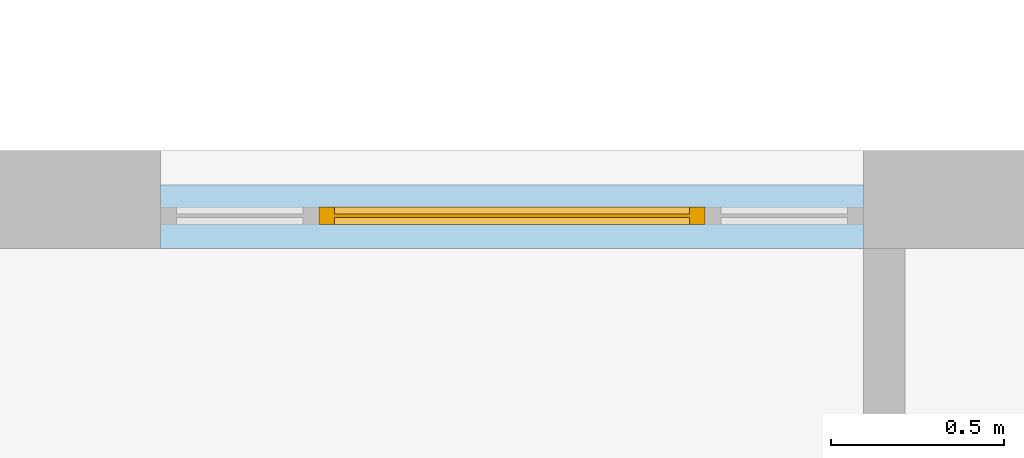
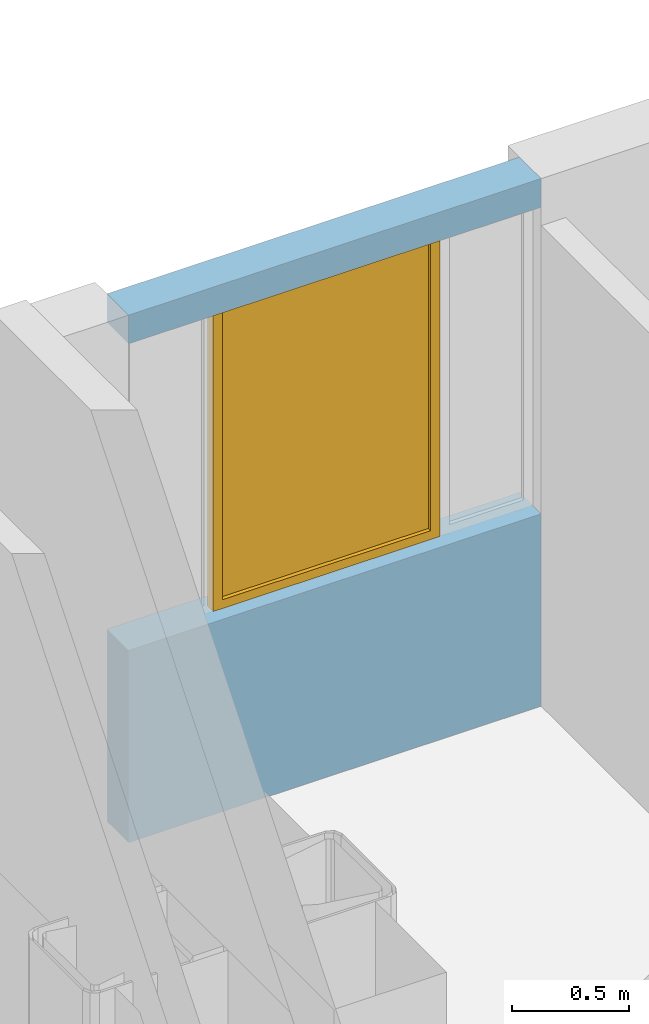
# One storey, part 19 of 64: 1 window, 3 openings, plus 1 element that does not belong to this part.
"""IFC4 building model written with IfcOpenShell, lengths in feet."""

from ifc_helpers import new_model, entity, si_unit, converted_unit, frame, origin_with_axes, origin_2d_with_axis, place, context, subcontext, project, spatial, line, indexed_curve, outline, extrude, polygons, source, transform, mapped, material, layer, layer_set, layer_usage, type_object, type_shapes, element, fill, save


model = new_model("IFC4")

# Units and contexts
model_context = context("Model", 3, precision=1e-05, world=origin_with_axes())
plan_context = context("Plan", 2, precision=1e-05, world=origin_2d_with_axis())
context_of_model_1 = context(None, 3, precision=1e-05, world=origin_with_axes())
context_of_model_2 = context(None, 3, precision=1e-05, world=origin_with_axes())
body_context = subcontext(model_context, "Body", "Model", "MODEL_VIEW")
ifc_project = project(units=[converted_unit("PLANEANGLEUNIT", "degree", entity("IfcReal", 0.0174532925199433), si_unit("PLANEANGLEUNIT", "RADIAN"), dimensions=[0, 0, 0, 0, 0, 0, 0]), converted_unit("AREAUNIT", "square foot", entity("IfcReal", 0.09290304), si_unit("AREAUNIT", "SQUARE_METRE"), dimensions=[2, 0, 0, 0, 0, 0, 0]), converted_unit("LENGTHUNIT", "foot", entity("IfcReal", 0.3048), si_unit("LENGTHUNIT", "METRE"), dimensions=[1, 0, 0, 0, 0, 0, 0]), converted_unit("VOLUMEUNIT", "cubic foot", entity("IfcReal", 0.0283168467116885), si_unit("VOLUMEUNIT", "CUBIC_METRE"), dimensions=[3, 0, 0, 0, 0, 0, 0])], contexts=[model_context, plan_context, context_of_model_1, context_of_model_2])

# Site, building, storey
site_placement = place(None, origin_with_axes())
site = spatial("IfcSite", under=ifc_project, at=site_placement)
building_placement = place(site_placement, origin_with_axes())
building = spatial("IfcBuilding", under=site, at=building_placement, Name="Building")
storey_placement = place(building_placement, origin_with_axes())
storey = spatial("IfcBuildingStorey", under=building, at=storey_placement, Name="Storey")

# Wall, openings, window
ifc_material_1 = material()
ifc_layer_1 = layer(ifc_material_1, 0.0520833333333333)
ifc_material_2 = material()
ifc_layer_2 = layer(ifc_material_2, 0.458332985639572)
ifc_layer_3 = layer(ifc_material_1, 0.0520833320915699)
ifc_material_3 = material(Name="SPACE")
ifc_layer_4 = layer(ifc_material_3, 0.0416669994592667, Name="Siding")
ifc_layer_set = layer_set([ifc_layer_1, ifc_layer_2, ifc_layer_3, ifc_layer_4], Name="poche")
ifc_layer_usage = layer_usage(ifc_layer_set, "AXIS2", "POSITIVE", 0.0)
wall_type = type_object("IfcWallType", PredefinedType="STANDARD", material=ifc_layer_set)
wall_placement = place(storey_placement, frame((-264.65418457672, 33.9619600240953, 0.0), z_axis=(0.0, 0.0, 1.0), x_axis=(1.0, 0.0, 0.0)))
wall = element("IfcWall", 1, at=wall_placement, inside=storey, type_object=wall_type, material=ifc_layer_usage, Name="Wall", context=body_context, shape_type="SweptSolid", body=[
    extrude(outline(indexed_curve([(0.0, 0.0), (0.0, 0.604166650523742), (6.65892436578507, 0.604166650523742), (6.65892436578507, 0.0), (0.0, 0.0)], self_intersect=False)), origin_with_axes(), (0.0, 0.0, 1.0), 9.00000020900736),
])
shared_shape_1 = source(origin_with_axes(), body_context, "Body", "SweptSolid", [
    extrude(outline(indexed_curve([(0.0, 0.0), (1.49999189376831, 0.0), (1.49999189376831, 5.23353862762451), (0.0, 5.23353862762451)], segments=[line(1, 2, 3, 4, 1)])), frame((0.0, -0.328083992004395, 0.0), z_axis=(0.0, -1.0, 0.0), x_axis=(1.0, 0.0, 0.0)), (0.0, 0.0, -1.0), 1.26033463072902),
])
opening_1_placement = place(wall_placement, frame((-3.49676543189026e-13, -2.91397119324188e-14, 3.28083989501312), z_axis=(0.0, 0.0, 1.0), x_axis=(1.0, 0.0, 0.0)))
element("IfcOpeningElement", 2, at=opening_1_placement, cuts=wall, Name="Opening", PredefinedType="OPENING", context=body_context, shape_type="MappedRepresentation", body=[
    mapped(shared_shape_1, transform((0.0, 0.0, 0.0), x_axis=(1.0, 0.0, 0.0), y_axis=(0.0, 1.0, 0.0), z_axis=(0.0, 0.0, 1.0), scale=1.0)),
])
opening_2_placement = place(wall_placement, frame((5.15891498155133, -2.91397119324188e-14, 3.28083989501312), z_axis=(0.0, 0.0, 1.0), x_axis=(1.0, 0.0, 0.0)))
element("IfcOpeningElement", 3, at=opening_2_placement, cuts=wall, Name="Opening", PredefinedType="OPENING", context=body_context, shape_type="MappedRepresentation", body=[
    mapped(shared_shape_1, transform((0.0, 0.0, 0.0), x_axis=(1.0, 0.0, 0.0), y_axis=(0.0, 1.0, 0.0), z_axis=(0.0, 0.0, 1.0), scale=1.0)),
])
shared_shape_2 = source(origin_with_axes(), body_context, "Body", "SweptSolid", [
    extrude(outline(indexed_curve([(0.0, 0.0), (3.65891289710999, 0.0), (3.65891289710999, 5.23353862762451), (0.0, 5.23353862762451)], segments=[line(1, 2, 3, 4, 1)])), frame((0.0, -0.328083992004395, 0.0), z_axis=(0.0, -1.0, 0.0), x_axis=(1.0, 0.0, 0.0)), (0.0, 0.0, -1.0), 1.26033463072902),
])
opening_3_placement = place(wall_placement, frame((1.49999703635033, -2.91397119324188e-14, 3.28083989501312), z_axis=(0.0, 0.0, 1.0), x_axis=(1.0, 0.0, 0.0)))
opening_3 = element("IfcOpeningElement", 4, at=opening_3_placement, cuts=wall, Name="Opening", PredefinedType="OPENING", context=body_context, shape_type="MappedRepresentation", body=[
    mapped(shared_shape_2, transform((0.0, 0.0, 0.0), x_axis=(1.0, 0.0, 0.0), y_axis=(0.0, 1.0, 0.0), z_axis=(0.0, 0.0, 1.0), scale=1.0)),
])
window_type = type_object("IfcWindowType", PartitioningType="NOTDEFINED", PredefinedType="NOTDEFINED")
shared_shape_3 = source(origin_with_axes(), body_context, "Body", "Tessellation", [
    polygons([(0.15000008046627, 0.164041996002197, 5.08353805541992), (0.15000008046627, 0.164041996002197, 0.149999901652336), (0.0, 0.164041996002197, 0.0), (0.0, 0.164041996002197, 5.23353862762451), (0.0, 0.0, 0.0), (0.0, 0.0, 5.23353862762451), (0.15000008046627, 7.7842932100225e-09, 5.08353805541992), (0.15000008046627, 7.7842932100225e-09, 0.149999901652336), (3.50891304016113, 5.23098115934317e-08, 5.08353805541992), (3.65891289710999, 6.00941092443463e-08, 0.0), (3.65891289710999, 6.00941092443463e-08, 5.23353862762451), (3.50891304016113, 5.23098115934317e-08, 0.149999901652336), (3.65891289710999, 0.164042055606842, 5.23353862762451), (3.65891289710999, 0.164042055606842, 0.0), (3.50891304016113, 0.164042055606842, 0.149999901652336), (3.50891304016113, 0.164042055606842, 5.08353805541992), (3.50891304016113, 0.0656168535351753, 0.149999901652336), (0.15000008046627, 0.0656168088316917, 5.08353805541992), (3.50891304016113, 0.0656168535351753, 5.08353805541992), (0.15000008046627, 0.0656168088316917, 0.149999901652336), (3.50891304016113, 0.0984252467751503, 5.08353805541992), (3.50891304016113, 0.0984252467751503, 0.149999901652336), (0.15000008046627, 0.0984252095222473, 0.149999901652336), (0.15000008046627, 0.0984252095222473, 5.08353805541992)], [[[2, 3, 1]], [[4, 1, 3]], [[5, 7, 6]], [[5, 8, 7]], [[10, 11, 9]], [[12, 10, 9]], [[7, 11, 6]], [[7, 9, 11]], [[8, 10, 12]], [[5, 10, 8]], [[14, 15, 13]], [[15, 16, 13]], [[16, 1, 13]], [[13, 1, 4]], [[14, 3, 2]], [[14, 2, 15]], [[3, 10, 5]], [[3, 14, 10]], [[11, 10, 14]], [[11, 14, 13]], [[8, 12, 15]], [[15, 2, 8]], [[15, 9, 16]], [[12, 9, 15]], [[4, 6, 11]], [[4, 11, 13]], [[5, 6, 4]], [[5, 4, 3]], [[1, 9, 7]], [[1, 16, 9]], [[7, 8, 2]], [[7, 2, 1]]]),
    polygons([(0.15000008046627, 0.164041996002197, 5.08353805541992), (0.15000008046627, 0.164041996002197, 0.149999901652336), (0.0, 0.164041996002197, 0.0), (0.0, 0.164041996002197, 5.23353862762451), (0.0, 0.0, 0.0), (0.0, 0.0, 5.23353862762451), (0.15000008046627, 7.7842932100225e-09, 5.08353805541992), (0.15000008046627, 7.7842932100225e-09, 0.149999901652336), (3.50891304016113, 5.23098115934317e-08, 5.08353805541992), (3.65891289710999, 6.00941092443463e-08, 0.0), (3.65891289710999, 6.00941092443463e-08, 5.23353862762451), (3.50891304016113, 5.23098115934317e-08, 0.149999901652336), (3.65891289710999, 0.164042055606842, 5.23353862762451), (3.65891289710999, 0.164042055606842, 0.0), (3.50891304016113, 0.164042055606842, 0.149999901652336), (3.50891304016113, 0.164042055606842, 5.08353805541992), (3.50891304016113, 0.0656168535351753, 0.149999901652336), (0.15000008046627, 0.0656168088316917, 5.08353805541992), (3.50891304016113, 0.0656168535351753, 5.08353805541992), (0.15000008046627, 0.0656168088316917, 0.149999901652336), (3.50891304016113, 0.0984252467751503, 5.08353805541992), (3.50891304016113, 0.0984252467751503, 0.149999901652336), (0.15000008046627, 0.0984252095222473, 0.149999901652336), (0.15000008046627, 0.0984252095222473, 5.08353805541992)], [[[17, 19, 18]], [[20, 17, 18]], [[22, 23, 21]], [[23, 24, 21]], [[19, 24, 18]], [[21, 24, 19]], [[18, 24, 20]], [[24, 23, 20]], [[23, 17, 20]], [[23, 22, 17]], [[21, 19, 17]], [[21, 17, 22]]]),
])
type_shapes(window_type, [shared_shape_3])
window_placement = place(opening_3_placement, frame((-4.66235390918701e-14, 0.229836136024455, 2.91397119324188e-15), z_axis=(0.0, 0.0, 1.0), x_axis=(1.0, 0.0, 0.0)))
window = element("IfcWindow", 5, at=window_placement, inside=storey, type_object=window_type, Name="Window", context=body_context, shape_type="MappedRepresentation", body=[
    mapped(shared_shape_3, transform((0.0, 0.0, 0.0), x_axis=(1.0, 0.0, 0.0), y_axis=(0.0, 1.0, 0.0), z_axis=(0.0, 0.0, 1.0), scale=1.0)),
])
fill(opening_3, window)

save(model, "model.ifc")
